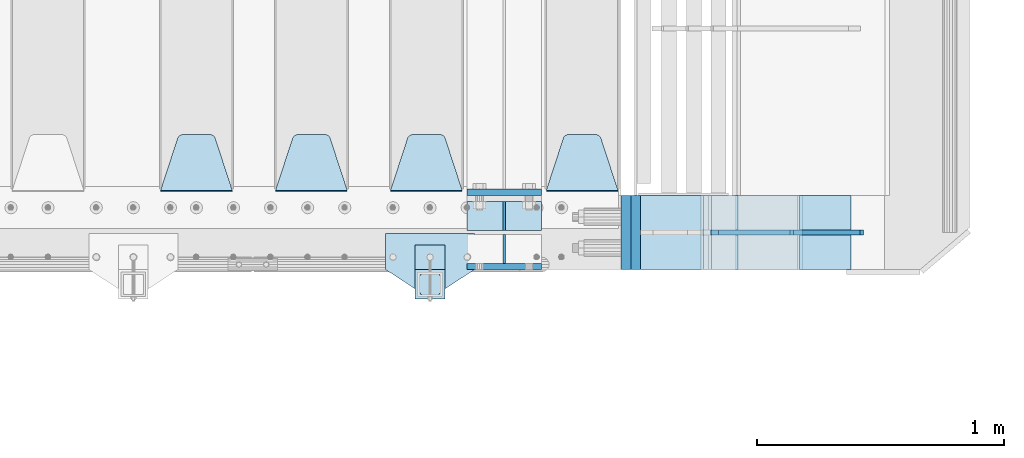
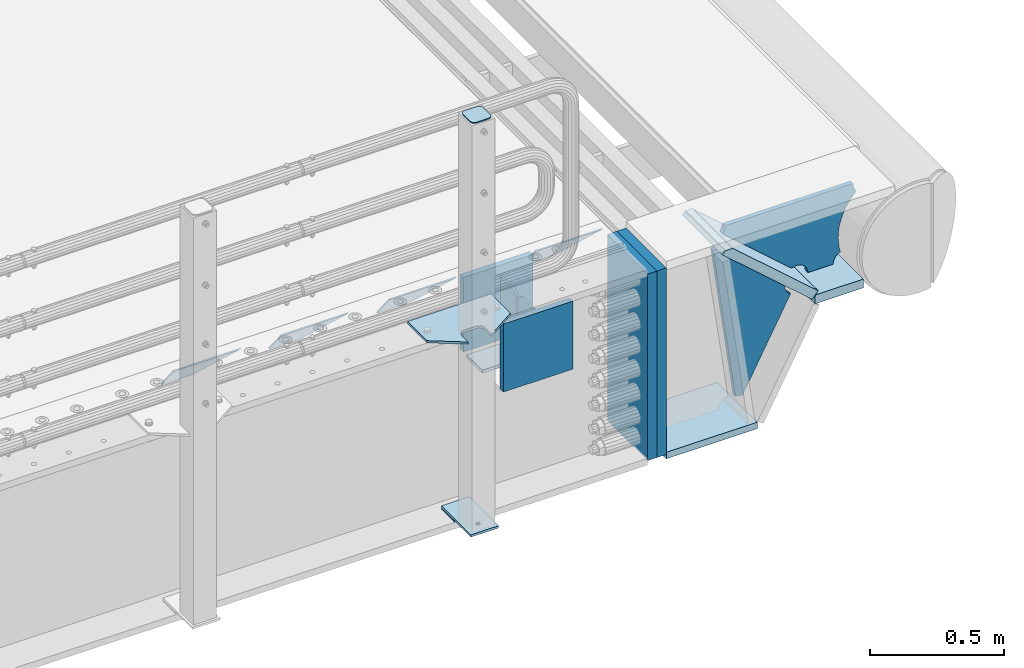
# One storey, part 234 of 257: 20 plates.
"""IFC2X3 building model written with IfcOpenShell, lengths in millimetres."""

from ifc_helpers import new_model, si_unit, frame, origin_with_axes, place, context, subcontext, project, spatial, faceted_brep, material, type_object, element, save


model = new_model("IFC2X3")

# Units and contexts
model_context = context("Model", 3, precision=1e-05, world=origin_with_axes())
body_context = subcontext(model_context, "Body", "Model", "MODEL_VIEW")
ifc_project = project(units=[si_unit("LENGTHUNIT", "METRE", prefix="MILLI"), si_unit("AREAUNIT", "SQUARE_METRE"), si_unit("VOLUMEUNIT", "CUBIC_METRE"), si_unit("MASSUNIT", "GRAM", prefix="KILO"), si_unit("TIMEUNIT", "SECOND"), si_unit("PLANEANGLEUNIT", "RADIAN"), si_unit("SOLIDANGLEUNIT", "STERADIAN"), si_unit("THERMODYNAMICTEMPERATUREUNIT", "DEGREE_CELSIUS"), si_unit("LUMINOUSINTENSITYUNIT", "LUMEN")], contexts=[model_context])

# Site, building, storey
site_placement = place(None, origin_with_axes())
site = spatial("IfcSite", under=ifc_project, at=site_placement, CompositionType="ELEMENT")
building_placement = place(site_placement, origin_with_axes())
building = spatial("IfcBuilding", under=site, at=building_placement, Name="Standard", CompositionType="ELEMENT")
storey_placement = place(building_placement, origin_with_axes())
storey = spatial("IfcBuildingStorey", under=building, at=storey_placement, Name="Undefined", CompositionType="ELEMENT", Elevation=0.0)

# Plates
ifc_material_1 = material(Name="STEEL/S355N")
plate_type_1 = type_object("IfcPlateType", PredefinedType="NOTDEFINED")
plate_1_placement = place(storey_placement, frame((58645.0, -137.500000000013, -339.999999999993), z_axis=(0.0, 0.0, 1.0), x_axis=(1.0, 0.0, 0.0)))
element("IfcPlate", 1, at=plate_1_placement, inside=storey, type_object=plate_type_1, material=ifc_material_1, context=body_context, shape_type="Brep", body=[
    faceted_brep([(0.0, -12.5, 0.0), (0.0, -12.5, 310.0), (0.0, 12.5, 310.0), (0.0, 12.5, 0.0), (300.0, -12.5, 310.0), (300.0, 12.5, 310.0), (300.0, -12.5, 0.0), (300.0, 12.5, 0.0)], [[[0, 1, 2, 3]], [[1, 4, 5, 2]], [[4, 6, 7, 5]], [[6, 0, 3, 7]], [[5, 7, 3, 2]], [[6, 4, 1, 0]]]),
])
plate_2_placement = place(storey_placement, frame((58645.0, 162.5, -340.000000000044), z_axis=(0.0, 0.0, 1.0), x_axis=(1.0, 0.0, 0.0)))
element("IfcPlate", 2, at=plate_2_placement, inside=storey, type_object=plate_type_1, material=ifc_material_1, context=body_context, shape_type="Brep", body=[
    faceted_brep([(0.0, -12.5, 0.0), (0.0, -12.5, 340.0), (0.0, 12.5, 340.0), (0.0, 12.5, 0.0), (300.0, -12.5, 340.0), (300.0, 12.5, 340.0), (300.0, -12.5, 0.0), (300.0, 12.5, 0.0)], [[[0, 1, 2, 3]], [[1, 4, 5, 2]], [[4, 6, 7, 5]], [[6, 0, 3, 7]], [[5, 7, 3, 2]], [[6, 4, 1, 0]]]),
])
plate_type_2 = type_object("IfcPlateType", PredefinedType="NOTDEFINED")
plate_3_placement = place(storey_placement, frame((58645.0, 7.9999999999867, -342.999999999993), z_axis=(0.0, 1.0, 0.0), x_axis=(1.0, 0.0, 0.0)))
element("IfcPlate", 3, at=plate_3_placement, inside=storey, type_object=plate_type_2, material=ifc_material_1, context=body_context, shape_type="Brep", body=[
    faceted_brep([(0.0, -7.0, 0.0), (0.0, -7.0, 117.0), (0.0, 7.0, 117.0), (0.0, 7.0, 0.0), (300.0, -7.0, 117.0), (300.0, 7.0, 117.0), (300.0, -7.0, 0.0), (300.0, 7.0, 0.0)], [[[0, 1, 2, 3]], [[1, 4, 5, 2]], [[4, 6, 7, 5]], [[6, 0, 3, 7]], [[5, 7, 3, 2]], [[6, 4, 1, 0]]]),
])
plate_type_3 = type_object("IfcPlateType", PredefinedType="NOTDEFINED")
for number, where, z_axis, x_axis in (
    (4, (58795.0, 7.9999999999867, -29.999999999993), (0.0, 0.0, -1.0), (0.0, 1.0, 0.0)),
    (5, (58795.0, -8.0000000000133, -29.999999999993), (0.0, 0.0, -1.0), (0.0, -1.0, 0.0)),
):
    element("IfcPlate", number, at=place(storey_placement, frame(where, z_axis=z_axis, x_axis=x_axis)), inside=storey, type_object=plate_type_3, material=ifc_material_1, context=body_context, shape_type="Brep", body=[
        faceted_brep([(0.0, -5.0, 30.0), (0.0, -5.0, 306.0), (0.0, 5.0, 306.0), (0.0, 5.0, 30.0), (117.0, -5.0, 306.0), (117.0, 5.0, 306.0), (117.0, -5.0, 0.0), (117.0, 5.0, 0.0), (30.0, -5.0, 0.0), (30.0, 5.0, 0.0), (24.7905546699922, -5.0, 0.455767409633758), (24.7905546699922, 5.0, 0.455767409633758), (19.7393957002296, -5.0, 1.80922137642275), (19.7393957002296, 5.0, 1.80922137642275), (15.0, -5.0, 4.01923788646684), (15.0, 5.0, 4.01923788646684), (10.7163717094036, -5.0, 7.01866670643066), (10.7163717094036, 5.0, 7.01866670643066), (7.01866670643085, -5.0, 10.7163717094038), (7.01866670643085, 5.0, 10.7163717094038), (4.01923788646673, -5.0, 15.0), (4.01923788646673, 5.0, 15.0), (1.80922137642301, -5.0, 19.7393957002299), (1.80922137642301, 5.0, 19.7393957002299), (0.455767409634063, -5.0, 24.7905546699921), (0.455767409634063, 5.0, 24.7905546699921)], [[[0, 1, 2, 3]], [[1, 4, 5, 2]], [[4, 6, 7, 5]], [[6, 8, 9, 7]], [[8, 10, 11, 9]], [[10, 12, 13, 11]], [[12, 14, 15, 13]], [[14, 16, 17, 15]], [[16, 18, 19, 17]], [[18, 20, 21, 19]], [[20, 22, 23, 21]], [[22, 24, 25, 23]], [[24, 0, 3, 25]], [[5, 7, 9, 11, 13, 15, 17, 19, 21, 23, 25, 3, 2]], [[24, 22, 20, 18, 16, 14, 12, 10, 8, 6, 4, 1, 0]]]),
    ])
plate_type_4 = type_object("IfcPlateType", PredefinedType="NOTDEFINED")
plate_4_placement = place(storey_placement, frame((59255.0, 168.232233047035, -1.76776695296758), z_axis=(0.0, 0.707106781186547, -0.707106781186548), x_axis=(-1.0, 0.0, 0.0)))
element("IfcPlate", 6, at=plate_4_placement, inside=storey, type_object=plate_type_4, material=ifc_material_1, context=body_context, shape_type="Brep", body=[
    faceted_brep([(0.0, -2.5, 0.0), (69.345504679477, -2.50000000000091, 300.17173142483), (69.345504679477, 2.5, 300.171731424831), (0.0, 2.5, 0.0), (70.927406119954, -2.50000000000091, 304.8974424154), (70.927406119954, 2.5, 304.8974424154), (73.3818627772271, -2.50000000000091, 309.234538108527), (73.3818627772271, 2.49999999999909, 309.234538108527), (76.6187032999587, -2.5, 313.023683126103), (76.6187032999587, 2.5, 313.023683126103), (80.5190132705029, -2.5, 316.125672595372), (80.5190132705029, 2.5, 316.125672595371), (84.9395038596849, -2.5, 318.426546230476), (84.9395038596849, 2.5, 318.426546230477), (89.7177759439219, -2.5, 319.841774983275), (89.7177759439219, 2.5, 319.841774983275), (94.6782862926484, -2.5, 320.319366455079), (94.6782862926484, 2.5, 320.319366455079), (195.321713707352, -2.5, 320.319366455079), (195.321713707352, 2.5, 320.319366455079), (200.282224056078, -2.5, 319.841774983275), (200.282224056078, 2.49999999999909, 319.841774983275), (205.060496140315, -2.5, 318.426546230476), (205.060496140315, 2.49999999999909, 318.426546230475), (209.480986729497, -2.5, 316.125672595371), (209.480986729497, 2.5, 316.125672595371), (213.381296700041, -2.50000000000091, 313.023683126102), (213.381296700041, 2.5, 313.023683126103), (216.618137222766, -2.50000000000091, 309.234538108527), (216.618137222766, 2.5, 309.234538108527), (219.072593880039, -2.5, 304.897442415399), (219.072593880039, 2.5, 304.897442415399), (220.654495320523, -2.50000000000091, 300.17173142483), (220.654495320523, 2.5, 300.171731424831), (290.0, -2.50000000000091, 0.0), (290.0, 2.5, 9.09494701772928e-13)], [[[0, 1, 2, 3]], [[1, 4, 5, 2]], [[4, 6, 7, 5]], [[6, 8, 9, 7]], [[8, 10, 11, 9]], [[10, 12, 13, 11]], [[12, 14, 15, 13]], [[14, 16, 17, 15]], [[16, 18, 19, 17]], [[18, 20, 21, 19]], [[20, 22, 23, 21]], [[22, 24, 25, 23]], [[24, 26, 27, 25]], [[26, 28, 29, 27]], [[28, 30, 31, 29]], [[30, 32, 33, 31]], [[32, 34, 35, 33]], [[34, 0, 3, 35]], [[5, 7, 9, 11, 13, 15, 17, 19, 21, 23, 25, 27, 29, 31, 33, 35, 3, 2]], [[34, 32, 30, 28, 26, 24, 22, 20, 18, 16, 14, 12, 10, 8, 6, 4, 1, 0]]]),
])
plate_5_placement = place(storey_placement, frame((58625.0, 168.232233047035, -1.76776695296758), z_axis=(0.0, 0.707106781186547, -0.707106781186548), x_axis=(-1.0, 0.0, 0.0)))
element("IfcPlate", 7, at=plate_5_placement, inside=storey, type_object=plate_type_4, material=ifc_material_1, context=body_context, shape_type="Brep", body=[
    faceted_brep([(0.0, -2.5, 0.0), (69.345504679477, -2.50000000000091, 300.17173142483), (69.345504679477, 2.5, 300.171731424831), (0.0, 2.5, 0.0), (70.927406119954, -2.50000000000091, 304.8974424154), (70.927406119954, 2.5, 304.8974424154), (73.3818627772271, -2.50000000000091, 309.234538108527), (73.3818627772271, 2.49999999999909, 309.234538108527), (76.6187032999587, -2.5, 313.023683126103), (76.6187032999587, 2.5, 313.023683126103), (80.5190132705029, -2.5, 316.125672595372), (80.5190132705029, 2.5, 316.125672595371), (84.9395038596849, -2.5, 318.426546230476), (84.9395038596849, 2.5, 318.426546230477), (89.7177759439219, -2.5, 319.841774983275), (89.7177759439219, 2.5, 319.841774983275), (94.6782862926484, -2.5, 320.319366455079), (94.6782862926484, 2.5, 320.319366455079), (195.321713707352, -2.5, 320.319366455079), (195.321713707352, 2.5, 320.319366455079), (200.282224056078, -2.5, 319.841774983275), (200.282224056078, 2.49999999999909, 319.841774983275), (205.060496140315, -2.5, 318.426546230476), (205.060496140315, 2.49999999999909, 318.426546230475), (209.480986729497, -2.5, 316.125672595371), (209.480986729497, 2.5, 316.125672595371), (213.381296700041, -2.50000000000091, 313.023683126102), (213.381296700041, 2.5, 313.023683126103), (216.618137222766, -2.50000000000091, 309.234538108527), (216.618137222766, 2.5, 309.234538108527), (219.072593880039, -2.5, 304.897442415399), (219.072593880039, 2.5, 304.897442415399), (220.654495320523, -2.50000000000091, 300.17173142483), (220.654495320523, 2.5, 300.171731424831), (290.0, -2.50000000000091, 0.0), (290.0, 2.5, 9.09494701772928e-13)], [[[0, 1, 2, 3]], [[1, 4, 5, 2]], [[4, 6, 7, 5]], [[6, 8, 9, 7]], [[8, 10, 11, 9]], [[10, 12, 13, 11]], [[12, 14, 15, 13]], [[14, 16, 17, 15]], [[16, 18, 19, 17]], [[18, 20, 21, 19]], [[20, 22, 23, 21]], [[22, 24, 25, 23]], [[24, 26, 27, 25]], [[26, 28, 29, 27]], [[28, 30, 31, 29]], [[30, 32, 33, 31]], [[32, 34, 35, 33]], [[34, 0, 3, 35]], [[5, 7, 9, 11, 13, 15, 17, 19, 21, 23, 25, 27, 29, 31, 33, 35, 3, 2]], [[34, 32, 30, 28, 26, 24, 22, 20, 18, 16, 14, 12, 10, 8, 6, 4, 1, 0]]]),
])
plate_6_placement = place(storey_placement, frame((58160.0, 168.232233047035, -1.76776695296758), z_axis=(0.0, 0.707106781186547, -0.707106781186548), x_axis=(-1.0, 0.0, 0.0)))
element("IfcPlate", 8, at=plate_6_placement, inside=storey, type_object=plate_type_4, material=ifc_material_1, context=body_context, shape_type="Brep", body=[
    faceted_brep([(0.0, -2.5, 0.0), (69.345504679477, -2.50000000000091, 300.17173142483), (69.345504679477, 2.5, 300.171731424831), (0.0, 2.5, 0.0), (70.927406119954, -2.50000000000091, 304.8974424154), (70.927406119954, 2.5, 304.8974424154), (73.3818627772271, -2.50000000000091, 309.234538108527), (73.3818627772271, 2.49999999999909, 309.234538108527), (76.6187032999587, -2.5, 313.023683126103), (76.6187032999587, 2.5, 313.023683126103), (80.5190132705029, -2.5, 316.125672595372), (80.5190132705029, 2.5, 316.125672595371), (84.9395038596849, -2.5, 318.426546230476), (84.9395038596849, 2.5, 318.426546230477), (89.7177759439219, -2.5, 319.841774983275), (89.7177759439219, 2.5, 319.841774983275), (94.6782862926484, -2.5, 320.319366455079), (94.6782862926484, 2.5, 320.319366455079), (195.321713707352, -2.5, 320.319366455079), (195.321713707352, 2.5, 320.319366455079), (200.282224056078, -2.5, 319.841774983275), (200.282224056078, 2.49999999999909, 319.841774983275), (205.060496140315, -2.5, 318.426546230476), (205.060496140315, 2.49999999999909, 318.426546230475), (209.480986729497, -2.5, 316.125672595371), (209.480986729497, 2.5, 316.125672595371), (213.381296700041, -2.50000000000091, 313.023683126102), (213.381296700041, 2.5, 313.023683126103), (216.618137222766, -2.50000000000091, 309.234538108527), (216.618137222766, 2.5, 309.234538108527), (219.072593880039, -2.5, 304.897442415399), (219.072593880039, 2.5, 304.897442415399), (220.654495320523, -2.50000000000091, 300.17173142483), (220.654495320523, 2.5, 300.171731424831), (290.0, -2.50000000000091, 0.0), (290.0, 2.5, 9.09494701772928e-13)], [[[0, 1, 2, 3]], [[1, 4, 5, 2]], [[4, 6, 7, 5]], [[6, 8, 9, 7]], [[8, 10, 11, 9]], [[10, 12, 13, 11]], [[12, 14, 15, 13]], [[14, 16, 17, 15]], [[16, 18, 19, 17]], [[18, 20, 21, 19]], [[20, 22, 23, 21]], [[22, 24, 25, 23]], [[24, 26, 27, 25]], [[26, 28, 29, 27]], [[28, 30, 31, 29]], [[30, 32, 33, 31]], [[32, 34, 35, 33]], [[34, 0, 3, 35]], [[5, 7, 9, 11, 13, 15, 17, 19, 21, 23, 25, 27, 29, 31, 33, 35, 3, 2]], [[34, 32, 30, 28, 26, 24, 22, 20, 18, 16, 14, 12, 10, 8, 6, 4, 1, 0]]]),
])
plate_7_placement = place(storey_placement, frame((57695.0, 168.232233047035, -1.76776695296758), z_axis=(0.0, 0.707106781186547, -0.707106781186548), x_axis=(-1.0, 0.0, 0.0)))
element("IfcPlate", 9, at=plate_7_placement, inside=storey, type_object=plate_type_4, material=ifc_material_1, context=body_context, shape_type="Brep", body=[
    faceted_brep([(0.0, -2.5, 0.0), (69.345504679477, -2.50000000000091, 300.17173142483), (69.345504679477, 2.5, 300.171731424831), (0.0, 2.5, 0.0), (70.927406119954, -2.50000000000091, 304.8974424154), (70.927406119954, 2.5, 304.8974424154), (73.3818627772271, -2.50000000000091, 309.234538108527), (73.3818627772271, 2.49999999999909, 309.234538108527), (76.6187032999587, -2.5, 313.023683126103), (76.6187032999587, 2.5, 313.023683126103), (80.5190132705029, -2.5, 316.125672595372), (80.5190132705029, 2.5, 316.125672595371), (84.9395038596849, -2.5, 318.426546230476), (84.9395038596849, 2.5, 318.426546230477), (89.7177759439219, -2.5, 319.841774983275), (89.7177759439219, 2.5, 319.841774983275), (94.6782862926484, -2.5, 320.319366455079), (94.6782862926484, 2.5, 320.319366455079), (195.321713707352, -2.5, 320.319366455079), (195.321713707352, 2.5, 320.319366455079), (200.282224056078, -2.5, 319.841774983275), (200.282224056078, 2.49999999999909, 319.841774983275), (205.060496140315, -2.5, 318.426546230476), (205.060496140315, 2.49999999999909, 318.426546230475), (209.480986729497, -2.5, 316.125672595371), (209.480986729497, 2.5, 316.125672595371), (213.381296700041, -2.50000000000091, 313.023683126102), (213.381296700041, 2.5, 313.023683126103), (216.618137222766, -2.50000000000091, 309.234538108527), (216.618137222766, 2.5, 309.234538108527), (219.072593880039, -2.5, 304.897442415399), (219.072593880039, 2.5, 304.897442415399), (220.654495320523, -2.50000000000091, 300.17173142483), (220.654495320523, 2.5, 300.171731424831), (290.0, -2.50000000000091, 0.0), (290.0, 2.5, 9.09494701772928e-13)], [[[0, 1, 2, 3]], [[1, 4, 5, 2]], [[4, 6, 7, 5]], [[6, 8, 9, 7]], [[8, 10, 11, 9]], [[10, 12, 13, 11]], [[12, 14, 15, 13]], [[14, 16, 17, 15]], [[16, 18, 19, 17]], [[18, 20, 21, 19]], [[20, 22, 23, 21]], [[22, 24, 25, 23]], [[24, 26, 27, 25]], [[26, 28, 29, 27]], [[28, 30, 31, 29]], [[30, 32, 33, 31]], [[32, 34, 35, 33]], [[34, 0, 3, 35]], [[5, 7, 9, 11, 13, 15, 17, 19, 21, 23, 25, 27, 29, 31, 33, 35, 3, 2]], [[34, 32, 30, 28, 26, 24, 22, 20, 18, 16, 14, 12, 10, 8, 6, 4, 1, 0]]]),
])
plate_type_5 = type_object("IfcPlateType", PredefinedType="NOTDEFINED")
plate_8_placement = place(storey_placement, frame((59988.9988298899, 149.9999999992, -367.999999998666), z_axis=(-0.752989422949573, 0.0, 0.658032619955933), x_axis=(0.0, -1.0, 0.0)))
element("IfcPlate", 10, at=plate_8_placement, inside=storey, type_object=plate_type_5, material=ifc_material_1, context=body_context, shape_type="Brep", body=[
    faceted_brep([(-8.10757683211705e-10, 20.0, 490.766265601618), (4.54747350886464e-13, -0.303811250938452, 513.999999999993), (300.0, -0.303811250938452, 513.999999999993), (300.0, 20.0, 490.766265601618), (300.0, -20.0, -1.81898940354586e-12), (300.0, -19.9999999999927, 513.999999999993), (4.54747350886464e-13, -19.9999999999927, 513.999999999993), (0.0, -20.0, 0.0), (0.0, 20.0, 0.0), (300.0, 20.0, -1.81898940354586e-12)], [[[0, 1, 2, 3]], [[4, 5, 6, 7]], [[4, 7, 8, 9]], [[9, 8, 0, 3]], [[5, 4, 9, 3, 2]], [[6, 5, 2, 1]], [[8, 7, 6, 1, 0]]]),
])
ifc_material_2 = material()
for number, where, z_axis, x_axis in (
    (11, (59326.9988298907, 150.0, -869.999999999366), (0.0, 0.0, 1.0), (0.0, -1.0, 0.0)),
    (12, (59287.0, 150.0, -870.0), (0.0, 0.0, 1.0), (0.0, -1.0, 0.0)),
):
    element("IfcPlate", number, at=place(storey_placement, frame(where, z_axis=z_axis, x_axis=x_axis)), inside=storey, type_object=plate_type_5, material=ifc_material_2, context=body_context, shape_type="Brep", body=[
        faceted_brep([(0.0, -20.0, 0.0), (0.0, -20.0, 850.0), (0.0, 20.0, 850.0), (0.0, 20.0, 0.0), (300.0, -20.0, 850.0), (300.0, 20.0, 850.0), (300.0, -20.0, -1.81898940354586e-12), (300.0, 20.0, -1.81898940354586e-12)], [[[0, 1, 2, 3]], [[1, 4, 5, 2]], [[4, 6, 7, 5]], [[6, 0, 3, 7]], [[5, 7, 3, 2]], [[6, 4, 1, 0]]]),
    ])
ifc_material_3 = material(Name="STEEL/S355J2")
plate_type_6 = type_object("IfcPlateType", PredefinedType="NOTDEFINED")
plate_9_placement = place(storey_placement, frame((58675.0, -4.99999999999636, 5.00000000004911), z_axis=(0.0, -1.0, 0.0), x_axis=(-1.0, 0.0, 0.0)))
element("IfcPlate", 13, at=plate_9_placement, inside=storey, type_object=plate_type_6, material=ifc_material_3, context=body_context, shape_type="Brep", body=[
    faceted_brep([(0.0, -5.0, 0.0), (2.31396552408114e-06, -5.0, 145.0), (2.31396552408114e-06, 5.0, 145.0), (0.0, 5.0, 0.0), (130.0, -5.0, 230.0), (130.0, 5.0, 230.0), (130.0, -5.0, 180.0), (130.0, 5.0, 180.0), (130.48036798992, -5.0, 175.122741949597), (130.48036798992, 5.0, 175.122741949597), (131.903011687216, -5.0, 170.432914190873), (131.903011687216, 5.0, 170.432914190873), (134.213259692435, -5.0, 166.11074417451), (134.213259692435, 5.0, 166.11074417451), (137.322330470335, -5.0, 162.322330470337), (137.322330470335, 5.0, 162.322330470337), (141.110744174512, -5.0, 159.213259692437), (141.110744174512, 5.0, 159.213259692437), (145.432914190875, -5.0, 156.903011687218), (145.432914190875, 5.0, 156.903011687218), (150.122741949599, -5.0, 155.48036798992), (150.122741949599, 5.0, 155.48036798992), (155.0, -5.0, 155.0), (155.0, 5.0, 155.0), (205.0, -5.0, 155.0), (205.0, 5.0, 155.0), (209.877258050401, -5.0, 155.48036798992), (209.877258050401, 5.0, 155.48036798992), (214.567085809125, -5.0, 156.903011687218), (214.567085809125, 5.0, 156.903011687218), (218.889255825488, -5.0, 159.213259692437), (218.889255825488, 5.0, 159.213259692437), (222.677669529665, -5.0, 162.322330470337), (222.677669529665, 5.0, 162.322330470337), (225.786740307565, -5.0, 166.11074417451), (225.786740307565, 5.0, 166.11074417451), (228.096988312784, -5.0, 170.432914190873), (228.096988312784, 5.0, 170.432914190873), (229.51963201008, -5.0, 175.122741949597), (229.51963201008, 5.0, 175.122741949597), (230.0, -5.0, 180.0), (230.0, 5.0, 180.0), (230.0, -5.0, 230.0), (230.0, 5.0, 230.0), (360.0, -5.0, 145.0), (360.0, 5.0, 145.0), (360.0, -5.0, -7.27595761418343e-12), (360.0, 5.0, -7.27595761418343e-12)], [[[0, 1, 2, 3]], [[1, 4, 5, 2]], [[4, 6, 7, 5]], [[6, 8, 9, 7]], [[8, 10, 11, 9]], [[10, 12, 13, 11]], [[12, 14, 15, 13]], [[14, 16, 17, 15]], [[16, 18, 19, 17]], [[18, 20, 21, 19]], [[20, 22, 23, 21]], [[22, 24, 25, 23]], [[24, 26, 27, 25]], [[26, 28, 29, 27]], [[28, 30, 31, 29]], [[30, 32, 33, 31]], [[32, 34, 35, 33]], [[34, 36, 37, 35]], [[36, 38, 39, 37]], [[38, 40, 41, 39]], [[40, 42, 43, 41]], [[42, 44, 45, 43]], [[44, 46, 47, 45]], [[46, 0, 3, 47]], [[5, 7, 9, 11, 13, 15, 17, 19, 21, 23, 25, 27, 29, 31, 33, 35, 37, 39, 41, 43, 45, 47, 3, 2]], [[46, 44, 42, 40, 38, 36, 34, 32, 30, 28, 26, 24, 22, 20, 18, 16, 14, 12, 10, 8, 6, 4, 1, 0]]]),
])
plate_type_7 = type_object("IfcPlateType", PredefinedType="NOTDEFINED")
plate_10_placement = place(storey_placement, frame((58554.9999999999, -50.0000000002074, -850.000000000002), z_axis=(0.0, -1.0, 0.0), x_axis=(-1.0, 0.0, 0.0)))
element("IfcPlate", 14, at=plate_10_placement, inside=storey, type_object=plate_type_7, material=ifc_material_3, context=body_context, shape_type="Brep", body=[
    faceted_brep([(53.6360389691836, -5.0, 176.363961030469), (53.6360389691836, 5.0, 176.363961030469), (59.9999999998618, 5.0, 178.999999999791), (59.9999999998618, -5.0, 178.999999999791), (66.3639610305399, 5.0, 176.363961030469), (66.3639610305399, -5.0, 176.363961030469), (68.9999999998618, 5.0, 169.999999999791), (68.9999999998618, -5.0, 169.999999999791), (66.3639610305399, 5.0, 163.636038969113), (66.3639610305399, -5.0, 163.636038969113), (59.9999999998618, 5.0, 160.999999999791), (59.9999999998618, -5.0, 160.999999999791), (53.6360389691836, 5.0, 163.636038969113), (53.6360389691836, -5.0, 163.636038969113), (50.9999999998618, 5.0, 169.999999999791), (50.9999999998618, -5.0, 169.999999999791), (120.0, -5.0, 0.0), (120.0, -5.0, 220.0), (0.0, -5.0, 220.0), (0.0, -5.0, 0.0), (0.0, 5.0, 0.0), (120.0, 5.0, 0.0), (120.0, 5.0, 220.0), (0.0, 5.0, 220.0)], [[[0, 1, 2, 3]], [[3, 2, 4, 5]], [[5, 4, 6, 7]], [[7, 6, 8, 9]], [[9, 8, 10, 11]], [[11, 10, 12, 13]], [[13, 12, 14, 15]], [[15, 14, 1, 0]], [[16, 17, 18, 19], [11, 13, 15, 0, 3, 5, 7, 9]], [[16, 19, 20, 21]], [[17, 16, 21, 22]], [[18, 17, 22, 23]], [[19, 18, 23, 20]], [[22, 21, 20, 23], [2, 1, 14, 12, 10, 8, 6, 4]]]),
])
plate_type_8 = type_object("IfcPlateType", PredefinedType="NOTDEFINED")
plate_11_placement = place(storey_placement, frame((58450.9999999999, -166.000000000207, 1012.50000000001), z_axis=(0.0, -1.0, 0.0), x_axis=(1.0, 0.0, 0.0)))
element("IfcPlate", 15, at=plate_11_placement, inside=storey, type_object=plate_type_8, material=ifc_material_3, context=body_context, shape_type="Brep", body=[
    faceted_brep([(0.0, -2.5, 19.0), (0.0, -2.5, 69.0), (0.0, 2.5, 69.0), (0.0, 2.5, 19.0), (0.476369668547704, -2.5, 73.2278977451697), (0.476369668547704, 2.5, 73.2278977451697), (1.88159150985302, -2.5, 77.2437910432327), (1.88159150985302, 2.5, 77.2437910432327), (4.14520183311106, -2.5, 80.8463062353167), (4.14520183311106, 2.5, 80.8463062353167), (7.15369376468152, -2.5, 83.8547981668926), (7.15369376468152, 2.5, 83.8547981668926), (10.7562089567655, -2.5, 86.1184084901452), (10.7562089567655, 2.5, 86.1184084901452), (14.7721022548285, -2.5, 87.5236303314541), (14.7721022548285, 2.5, 87.5236303314541), (19.0, -2.5, 88.0), (19.0, 2.5, 88.0), (69.0, -2.5, 88.0), (69.0, 2.5, 88.0), (73.2278977451715, -2.5, 87.5236303314541), (73.2278977451715, 2.5, 87.5236303314541), (77.2437910432345, -2.5, 86.1184084901452), (77.2437910432345, 2.5, 86.1184084901452), (80.8463062353185, -2.5, 83.8547981668926), (80.8463062353185, 2.5, 83.8547981668926), (83.8547981668889, -2.5, 80.8463062353167), (83.8547981668889, 2.5, 80.8463062353167), (86.118408490147, -2.5, 77.2437910432327), (86.118408490147, 2.5, 77.2437910432327), (87.5236303314523, -2.5, 73.2278977451697), (87.5236303314523, 2.5, 73.2278977451697), (88.0, -2.5, 69.0), (88.0, 2.5, 69.0), (88.0, -2.5, 19.0), (88.0, 2.5, 19.0), (87.5236303314523, -2.5, 14.7721022548303), (87.5236303314523, 2.5, 14.7721022548303), (86.118408490147, -2.5, 10.7562089567673), (86.118408490147, 2.5, 10.7562089567673), (83.8547981668889, -2.5, 7.15369376468334), (83.8547981668889, 2.5, 7.15369376468334), (80.8463062353185, -2.5, 4.14520183310742), (80.8463062353185, 2.5, 4.14520183310742), (77.2437910432345, -2.5, 1.88159150985484), (77.2437910432345, 2.5, 1.88159150985484), (73.2278977451715, -2.5, 0.476369668545885), (73.2278977451715, 2.5, 0.476369668545885), (69.0, -2.5, 0.0), (69.0, 2.5, 0.0), (19.0, -2.5, 0.0), (19.0, 2.5, 0.0), (14.7721022548285, -2.5, 0.476369668545885), (14.7721022548285, 2.5, 0.476369668545885), (10.7562089567655, -2.5, 1.88159150985484), (10.7562089567655, 2.5, 1.88159150985484), (7.15369376468152, -2.5, 4.14520183310742), (7.15369376468152, 2.5, 4.14520183310742), (4.14520183311106, -2.5, 7.15369376468334), (4.14520183311106, 2.5, 7.15369376468334), (1.88159150985302, -2.5, 10.7562089567673), (1.88159150985302, 2.5, 10.7562089567673), (0.476369668547704, -2.5, 14.7721022548303), (0.476369668547704, 2.5, 14.7721022548303)], [[[0, 1, 2, 3]], [[1, 4, 5, 2]], [[4, 6, 7, 5]], [[6, 8, 9, 7]], [[8, 10, 11, 9]], [[10, 12, 13, 11]], [[12, 14, 15, 13]], [[14, 16, 17, 15]], [[16, 18, 19, 17]], [[18, 20, 21, 19]], [[20, 22, 23, 21]], [[22, 24, 25, 23]], [[24, 26, 27, 25]], [[26, 28, 29, 27]], [[28, 30, 31, 29]], [[30, 32, 33, 31]], [[32, 34, 35, 33]], [[34, 36, 37, 35]], [[36, 38, 39, 37]], [[38, 40, 41, 39]], [[40, 42, 43, 41]], [[42, 44, 45, 43]], [[44, 46, 47, 45]], [[46, 48, 49, 47]], [[48, 50, 51, 49]], [[50, 52, 53, 51]], [[52, 54, 55, 53]], [[54, 56, 57, 55]], [[56, 58, 59, 57]], [[58, 60, 61, 59]], [[60, 62, 63, 61]], [[62, 0, 3, 63]], [[5, 7, 9, 11, 13, 15, 17, 19, 21, 23, 25, 27, 29, 31, 33, 35, 37, 39, 41, 43, 45, 47, 49, 51, 53, 55, 57, 59, 61, 63, 3, 2]], [[62, 60, 58, 56, 54, 52, 50, 48, 46, 44, 42, 40, 38, 36, 34, 32, 30, 28, 26, 24, 22, 20, 18, 16, 14, 12, 10, 8, 6, 4, 1, 0]]]),
])
plate_type_9 = type_object("IfcPlateType", PredefinedType="NOTDEFINED")
plate_12_placement = place(storey_placement, frame((58554.9999999999, -50.0000000002074, -857.500000000002), z_axis=(0.0, -1.0, 0.0), x_axis=(-1.0, 0.0, 0.0)))
element("IfcPlate", 16, at=plate_12_placement, inside=storey, type_object=plate_type_9, material=ifc_material_3, context=body_context, shape_type="Brep", body=[
    faceted_brep([(0.0, -2.5, 0.0), (0.0, -2.5, 100.0), (0.0, 2.5, 100.0), (0.0, 2.5, 0.0), (120.0, -2.5, 100.0), (120.0, 2.5, 100.0), (120.0, -2.5, 0.0), (120.0, 2.5, 0.0)], [[[0, 1, 2, 3]], [[1, 4, 5, 2]], [[4, 6, 7, 5]], [[6, 0, 3, 7]], [[5, 7, 3, 2]], [[6, 4, 1, 0]]]),
])
plate_type_10 = type_object("IfcPlateType", PredefinedType="NOTDEFINED")
plate_13_placement = place(storey_placement, frame((59988.9988298899, -150.000000000797, -387.999999998666), z_axis=(1.0, 0.0, 0.0), x_axis=(0.0, 1.0, 0.0)))
element("IfcPlate", 17, at=plate_13_placement, inside=storey, type_object=plate_type_10, material=ifc_material_1, context=body_context, shape_type="Brep", body=[
    faceted_brep([(0.0, -20.0, 0.0), (3.31056071445346e-10, -20.0, 208.0), (3.31056071445346e-10, 20.0, 208.0), (0.0, 20.0, 0.0), (300.0, -20.0, 208.0), (300.0, 20.0, 208.0), (300.0, -20.0, -1.81898940354586e-12), (300.0, 20.0, -1.81898940354586e-12)], [[[0, 1, 2, 3]], [[1, 4, 5, 2]], [[4, 6, 7, 5]], [[6, 0, 3, 7]], [[5, 7, 3, 2]], [[6, 4, 1, 0]]]),
])
plate_type_11 = type_object("IfcPlateType", PredefinedType="NOTDEFINED")
plate_14_placement = place(storey_placement, frame((59739.9988298892, 150.0, -875.000000002617), z_axis=(0.0, -1.0, 0.0), x_axis=(-1.0, 0.0, 0.0)))
element("IfcPlate", 18, at=plate_14_placement, inside=storey, type_object=plate_type_11, material=ifc_material_1, context=body_context, shape_type="Brep", body=[
    faceted_brep([(0.0, -15.0, 0.0), (0.0, -15.0, 300.0), (0.0, 15.0, 300.0), (0.0, 15.0, 0.0), (393.0, -15.0, 300.0), (393.0, 15.0, 300.0), (393.0, -15.0, 1.50635059981141e-12), (393.0, 15.0, 1.50635059981141e-12)], [[[0, 1, 2, 3]], [[1, 4, 5, 2]], [[4, 6, 7, 5]], [[6, 0, 3, 7]], [[5, 7, 3, 2]], [[6, 4, 1, 0]]]),
])
plate_type_12 = type_object("IfcPlateType", PredefinedType="NOTDEFINED")
plate_15_placement = place(storey_placement, frame((60303.9988298899, -6.40284270048141e-10, -29.9999999986662), z_axis=(-0.000446694000102124, 0.0, -0.99999990023223), x_axis=(-0.99999990023223, 0.0, 0.000446694000103734)))
element("IfcPlate", 19, at=plate_15_placement, inside=storey, type_object=plate_type_12, material=ifc_material_1, context=body_context, shape_type="Brep", body=[
    faceted_brep([(125.007775472979, 10.0, 291.842314882028), (131.755016800045, 10.0, 263.793234614468), (131.755016800045, -10.0, 263.793234614468), (125.007775472979, -10.0, 291.842314882028), (134.899927074475, 10.0, 224.060281342732), (134.899927074475, -10.0, 224.060281342732), (131.790514995213, 10.0, 184.324534302446), (131.790514995213, -10.0, 184.324534302446), (122.503344607198, 10.0, 145.564419461128), (122.503344607198, -10.0, 145.564419461128), (107.267096867741, 10.0, 108.734339483615), (107.267096867741, -10.0, 108.734339483615), (86.4569387623851, 10.0, 74.7411731709829), (86.4569387623851, -10.0, 74.7411731709829), (60.5852854486438, 10.0, 44.4219450946983), (60.5852854486438, -10.0, 44.4219450946983), (56.2519855253049, 10.0, 40.7176084148918), (56.2519855253049, -10.0, 40.7176084148918), (136.409234539118, -10.0, 297.721677540594), (147.386991180581, -10.0, 308.778803581017), (147.386991180581, 10.0, 308.778803581017), (136.409234539118, 10.0, 297.721677540594), (154.428166132762, -10.0, 322.678193223937), (154.428166132762, 10.0, 322.678193223937), (156.84900166298, -10.0, 338.070097995228), (156.84900166298, 10.0, 338.070097995228), (264.849004013289, -10.0, 338.118348049693), (264.849004013289, 10.0, 338.118348049693), (267.628767119546, -10.0, 321.701412969031), (267.628767119546, 10.0, 321.701412969031), (275.645118712171, -10.0, 307.107546191754), (275.645118712171, 10.0, 307.107546191754), (288.009068357205, -10.0, 295.955165748785), (288.009068357205, 10.0, 295.955165748785), (303.34948944753, -10.0, 289.481038692482), (303.34948944753, 10.0, 289.481038692482), (319.96517321693, -10.0, 288.403127172445), (319.96517321693, 10.0, 288.403127172445), (336.013487920231, -10.0, 292.840968489265), (336.013487920231, 10.0, 292.840968489265), (335.869079589844, -10.0, 293.150054931641), (335.869079589844, 10.0, 293.150054931641), (633.937057436437, -10.0, 32.8861672876965), (633.937057436437, 10.0, 32.8861672876965), (628.672097726398, -10.0, 25.6357574923157), (628.672097726398, 10.0, 25.6357574923157), (624.785781531267, -10.0, 17.5620477266101), (624.785781531267, 10.0, 17.5620477266101), (622.402919050604, -10.0, 8.92432757904926), (622.402919050604, 10.0, 8.92432757904926), (621.600036621094, -10.0, -8.74677219542264e-10), (621.600036621094, 10.0, -8.74677219542264e-10), (70.0, -10.0, -9.84980985663242e-11), (70.0, 10.0, -9.84980985663242e-11), (67.7728137216545, -10.0, 17.5170123094482), (67.7728137216545, 10.0, 17.5170123094482), (61.232979421402, -10.0, 33.9193489203215), (61.232979421402, 10.0, 33.9193489203215)], [[[0, 1, 2, 3]], [[4, 5, 2, 1]], [[6, 7, 5, 4]], [[8, 9, 7, 6]], [[10, 11, 9, 8]], [[12, 13, 11, 10]], [[14, 15, 13, 12]], [[16, 17, 15, 14]], [[18, 19, 20, 21]], [[19, 22, 23, 20]], [[22, 24, 25, 23]], [[24, 26, 27, 25]], [[26, 28, 29, 27]], [[28, 30, 31, 29]], [[30, 32, 33, 31]], [[32, 34, 35, 33]], [[34, 36, 37, 35]], [[36, 38, 39, 37]], [[38, 40, 41, 39]], [[40, 42, 43, 41]], [[42, 44, 45, 43]], [[44, 46, 47, 45]], [[46, 48, 49, 47]], [[48, 50, 51, 49]], [[50, 52, 53, 51]], [[52, 54, 55, 53]], [[54, 56, 57, 55]], [[12, 10, 8, 6, 4, 1, 0, 21, 20, 23, 25, 27, 29, 31, 33, 35, 37, 39, 41, 43, 45, 47, 49, 51, 53, 55, 57, 16, 14]], [[18, 21, 0, 3]], [[56, 54, 52, 50, 48, 46, 44, 42, 40, 38, 36, 34, 32, 30, 28, 26, 24, 22, 19, 18, 3, 2, 5, 7, 9, 11, 13, 15, 17]], [[57, 56, 17, 16]]]),
])
plate_type_13 = type_object("IfcPlateType", PredefinedType="NOTDEFINED")
plate_16_placement = place(storey_placement, frame((59988.0025685035, 1.00408215075731e-09, -393.996688203771), z_axis=(-0.658066357015093, 0.0, -0.752959939017266), x_axis=(-0.75295993901727, 0.0, 0.658066357015088)))
element("IfcPlate", 20, at=plate_16_placement, inside=storey, type_object=plate_type_13, material=ifc_material_1, context=body_context, shape_type="Brep", body=[
    faceted_brep([(-11.3595226159669, -10.0, 48.6925173505879), (-112.015767301047, -10.0, 480.154833723624), (-112.015767301047, 10.0, 480.154833723624), (-11.3595226159669, 10.0, 48.6925173505879), (-104.567323293646, -10.0, 482.519601382533), (-104.567323293646, 10.0, 482.519601382533), (-97.5783311600098, -10.0, 486.016090073754), (-97.5783311600098, 10.0, 486.016090073754), (-91.2195220373906, -10.0, 490.558885551647), (-91.2195220373906, 10.0, 490.558885551647), (-85.6462325884277, -10.0, 496.037013784), (-85.6462325884277, 10.0, 496.037013784), (447.024482710491, -10.0, 32.8103372896294), (447.024482710491, 10.0, 32.8103372896294), (441.786973010385, -10.0, 25.5709623937219), (441.786973010385, 10.0, 25.5709623937219), (437.921644570117, -10.0, 17.5149526624009), (437.921644570117, 10.0, 17.5149526624009), (435.551940606492, -10.0, 8.89958500531066), (435.551940606492, 10.0, 8.89958500531066), (434.753540039055, -10.0, -5.23868948221207e-10), (434.753540039055, 10.0, -5.23868948221207e-10), (50.0, -10.0, 0.0), (50.0, 10.0, 0.0), (47.7668538974176, -10.0, 14.7759151575083), (47.7668538974176, 10.0, 14.7759151575083), (41.2668932502784, -10.0, 28.231959221237), (41.2668932502784, 10.0, 28.231959221237), (31.080732530012, -10.0, 39.1661596968261), (31.080732530012, 10.0, 39.1661596968261), (18.1182591411343, -10.0, 46.6018098971836), (18.1182591411343, 10.0, 46.6018098971836), (3.53735696079821, -10.0, 49.8747140917258), (3.53735696079821, 10.0, 49.8747140917258)], [[[0, 1, 2, 3]], [[1, 4, 5, 2]], [[4, 6, 7, 5]], [[6, 8, 9, 7]], [[8, 10, 11, 9]], [[10, 12, 13, 11]], [[12, 14, 15, 13]], [[14, 16, 17, 15]], [[16, 18, 19, 17]], [[18, 20, 21, 19]], [[20, 22, 23, 21]], [[22, 24, 25, 23]], [[24, 26, 27, 25]], [[26, 28, 29, 27]], [[28, 30, 31, 29]], [[30, 32, 33, 31]], [[32, 0, 3, 33]], [[5, 7, 9, 11, 13, 15, 17, 19, 21, 23, 25, 27, 29, 31, 33, 3, 2]], [[32, 30, 28, 26, 24, 22, 20, 18, 16, 14, 12, 10, 8, 6, 4, 1, 0]]]),
])

save(model, "model.ifc")
